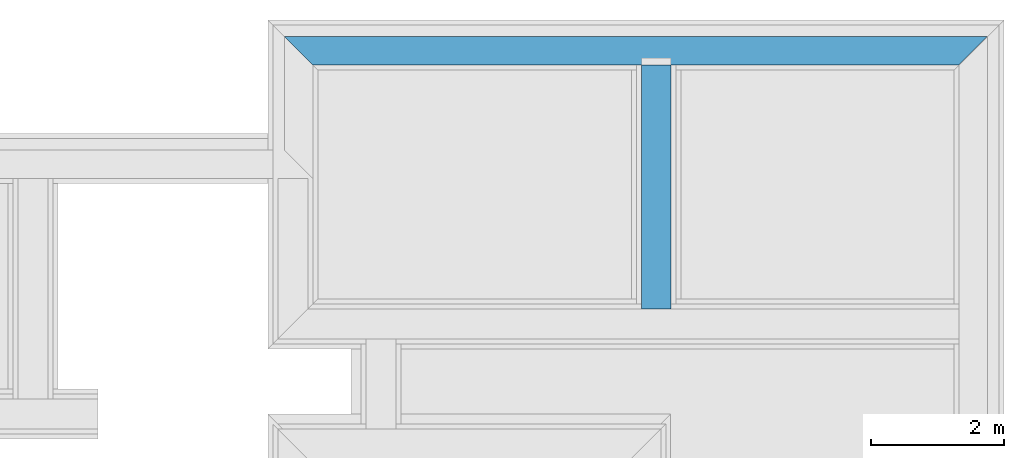
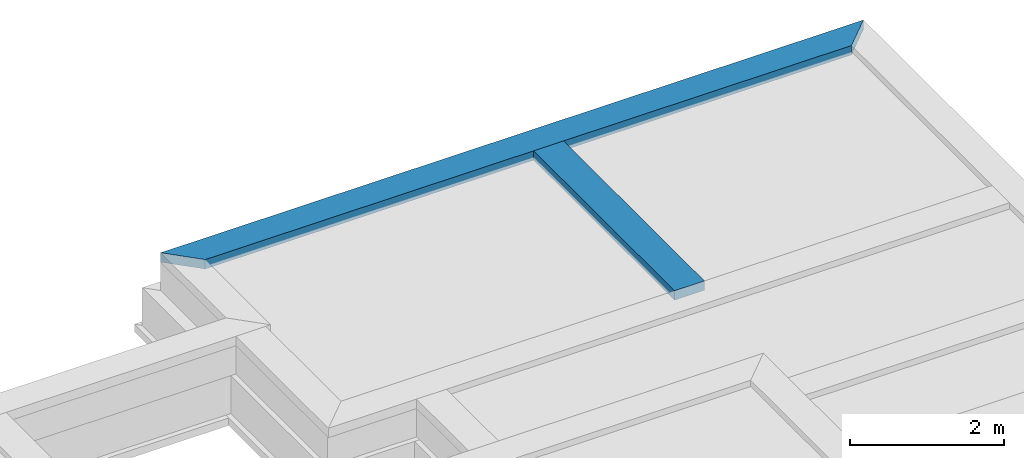
# One storey, part 2 of 7: 2 beams.
"""IFC4X3_ADD2 building model written with IfcOpenShell, lengths in metres."""

import ifcopenshell
import ifcopenshell.guid

model = None  # the IFC model being written
_history = None  # IfcOwnerHistory: only IFC2X3 demands one
_inside = {}  # id of a spatial element -> (the spatial element, [elements in it])
_under = {}  # id of a project, library or spatial element -> (it, [spatial elements below it])
_declared = {}  # id of a project -> (the project, [libraries it declares])
_typed = {}  # id of a type object -> (the type object, [elements of that type])
_made_of = {}  # id of a material, layer set ... -> (it, [elements and type objects made of it])


def new_model(schema):
    """Start an empty IFC model of exactly this schema.

    Asked for "IFC4X3", IfcOpenShell would pick the latest addendum, in which some entities
    have other attributes; the version numbers below select the first issue.
    IFC2X3 requires an IfcOwnerHistory on every rooted entity: one is made here for all.
    """
    global model, _history
    if schema == "IFC4X3":
        model = ifcopenshell.file(schema_version=(4, 3, 0, 0))
    else:
        model = ifcopenshell.file(schema=schema)
    _inside.clear()
    _under.clear()
    _declared.clear()
    _typed.clear()
    _made_of.clear()
    _history = None
    if model.schema == "IFC2X3":
        org = make("IfcOrganization", Name="unknown")
        user = make(
            "IfcPersonAndOrganization",
            ThePerson=make("IfcPerson", FamilyName="unknown"),
            TheOrganization=org,
        )
        app = make(
            "IfcApplication",
            ApplicationDeveloper=org,
            Version="unknown",
            ApplicationFullName="unknown",
            ApplicationIdentifier="unknown",
        )
        _history = make(
            "IfcOwnerHistory",
            OwningUser=user,
            OwningApplication=app,
            ChangeAction="ADDED",
            CreationDate=0,
        )
    return model


def make(cls, **values):
    """One entity of the class cls with the attributes given. An attribute that is None is left unset."""
    return model.create_entity(
        cls, **{name: value for name, value in values.items() if value is not None}
    )


def entity(cls, *values):
    """Any entity or typed value of the class cls, its attributes in the order of the schema. None: left unset."""
    e = model.create_entity(cls)
    for i, value in enumerate(values):
        if value is not None:
            e[i] = value
    return e


def rooted(cls, **values):
    """An entity with a GlobalId (a new one), such as an element, a storey or a relation."""
    return make(cls, GlobalId=ifcopenshell.guid.new(), OwnerHistory=_history, **values)


def si_unit(unit_type, name, prefix=None):
    """IfcSIUnit, for example si_unit("LENGTHUNIT", "METRE", prefix="MILLI")."""
    return make("IfcSIUnit", UnitType=unit_type, Prefix=prefix, Name=name)


def converted_unit(unit_type, name, factor, base, dimensions=None, offset=None):
    """IfcConversionBasedUnit, such as the inch: factor (a typed value) times the base unit."""
    return make(
        "IfcConversionBasedUnit"
        if offset is None
        else "IfcConversionBasedUnitWithOffset",
        ConversionOffset=offset,
        Dimensions=None
        if dimensions is None
        else entity("IfcDimensionalExponents", *dimensions),
        UnitType=unit_type,
        Name=name,
        ConversionFactor=make(
            "IfcMeasureWithUnit", ValueComponent=factor, UnitComponent=base
        ),
    )


def assignment(units):
    """IfcUnitAssignment: the units of a project."""
    return None if units is None else make("IfcUnitAssignment", Units=units)


def point(xyz):
    """IfcCartesianPoint."""
    return None if xyz is None else make("IfcCartesianPoint", Coordinates=xyz)


def direction(xyz):
    """IfcDirection."""
    return None if xyz is None else make("IfcDirection", DirectionRatios=xyz)


def frame(location, z_axis=None, x_axis=None):
    """IfcAxis2Placement3D, a coordinate frame: its origin and axes. An axis left out is left unset."""
    return make(
        "IfcAxis2Placement3D",
        Location=point(location),
        Axis=direction(z_axis),
        RefDirection=direction(x_axis),
    )


def frame_2d(location, x_axis=None):
    """IfcAxis2Placement2D, a coordinate frame in the plane: its origin and x axis."""
    return make(
        "IfcAxis2Placement2D", Location=point(location), RefDirection=direction(x_axis)
    )


def origin_with_axes():
    """The frame at (0, 0, 0) with the z axis (0, 0, 1) and the x axis (1, 0, 0) written out."""
    return frame((0.0, 0.0, 0.0), z_axis=(0.0, 0.0, 1.0), x_axis=(1.0, 0.0, 0.0))


def origin_2d_with_axis():
    """The frame at (0, 0) in the plane with the x axis (1, 0) written out."""
    return frame_2d((0.0, 0.0), x_axis=(1.0, 0.0))


def place(relative_to, where):
    """IfcLocalPlacement: puts the frame where relative to a parent placement (None: the world)."""
    return make(
        "IfcLocalPlacement", PlacementRelTo=relative_to, RelativePlacement=where
    )


def context(
    kind, dimensions, precision=None, world=None, true_north=None, identifier=None
):
    """IfcGeometricRepresentationContext, for example the 3D "Model" context."""
    return make(
        "IfcGeometricRepresentationContext",
        ContextIdentifier=identifier,
        ContextType=kind,
        CoordinateSpaceDimension=dimensions,
        Precision=precision,
        WorldCoordinateSystem=world,
        TrueNorth=true_north,
    )


def subcontext(parent, identifier, kind, view, scale=None):
    """IfcGeometricRepresentationSubContext, for example "Body" below "Model"."""
    return make(
        "IfcGeometricRepresentationSubContext",
        ContextIdentifier=identifier,
        ContextType=kind,
        ParentContext=parent,
        TargetScale=scale,
        TargetView=view,
    )


def project(units=None, contexts=None):
    """IfcProject with its units and contexts."""
    return rooted(
        "IfcProject",
        Name="project",
        RepresentationContexts=contexts,
        UnitsInContext=assignment(units),
    )


def spatial(cls, under=None, at=None, **own):
    """A site, building, storey or space (cls), placed at a placement, below another one or the project."""
    s = rooted(cls, ObjectPlacement=at, **own)
    if under is not None:
        _under.setdefault(under.id(), (under, []))[1].append(s)
    return s


def point_list(points):
    """IfcCartesianPointList2D or 3D."""
    cls = (
        "IfcCartesianPointList2D" if len(points[0]) == 2 else "IfcCartesianPointList3D"
    )
    return make(cls, CoordList=points)


def line(*indices):
    """IfcLineIndex: a straight run through numbered points of an indexed curve."""
    return model.create_entity("IfcLineIndex", indices)


def indexed_curve(points, segments=None, self_intersect=None):
    """IfcIndexedPolyCurve: lines and arcs through numbered points (the first is 1)."""
    return make(
        "IfcIndexedPolyCurve",
        Points=point_list(points),
        Segments=segments,
        SelfIntersect=self_intersect,
    )


def outline(outer, holes=None, kind="AREA"):
    """IfcArbitraryClosedProfileDef: a profile drawn as a closed curve; with holes, ...WithVoids."""
    if holes is None:
        return make("IfcArbitraryClosedProfileDef", ProfileType=kind, OuterCurve=outer)
    return make(
        "IfcArbitraryProfileDefWithVoids",
        ProfileType=kind,
        OuterCurve=outer,
        InnerCurves=holes,
    )


def extrude(swept, where, along, depth):
    """IfcExtrudedAreaSolid: the profile swept, set in the frame where, extruded along a direction by depth."""
    return make(
        "IfcExtrudedAreaSolid",
        SweptArea=swept,
        Position=where,
        ExtrudedDirection=direction(along),
        Depth=depth,
    )


def shape(context_of_items, identifier, shape_type, items):
    """IfcShapeRepresentation: the items that make up one representation, for example the "Body"."""
    return make(
        "IfcShapeRepresentation",
        ContextOfItems=context_of_items,
        RepresentationIdentifier=identifier,
        RepresentationType=shape_type,
        Items=items,
    )


def material(Name=None, Category=None):
    """IfcMaterial."""
    return make("IfcMaterial", Name=Name, Category=Category)


def layer(
    of_material, thickness, ventilated=None, Name=None, Category=None, Priority=None
):
    """IfcMaterialLayer: one layer of a wall or slab, of a material (None: an air gap)."""
    return make(
        "IfcMaterialLayer",
        Material=of_material,
        LayerThickness=thickness,
        IsVentilated=ventilated,
        Name=Name,
        Category=Category,
        Priority=Priority,
    )


def layer_set(layers, Name=None):
    """IfcMaterialLayerSet."""
    return make("IfcMaterialLayerSet", MaterialLayers=layers, LayerSetName=Name)


def layer_usage(for_layer_set, set_direction, sense, offset, extent=None):
    """IfcMaterialLayerSetUsage: how a layer set lies in its element."""
    return make(
        "IfcMaterialLayerSetUsage",
        ForLayerSet=for_layer_set,
        LayerSetDirection=set_direction,
        DirectionSense=sense,
        OffsetFromReferenceLine=offset,
        ReferenceExtent=extent,
    )


def made_of(thing, what):
    """Note that an element or type object is made of a material, layer set ...; save() writes the relation."""
    if what is not None:
        _made_of.setdefault(what.id(), (what, []))[1].append(thing)
    return thing


def type_object(cls, material=None, **own):
    """A type object (cls), such as IfcWallType, which elements share."""
    return made_of(rooted(cls, **own), material)


def element(
    cls,
    number,
    at=None,
    inside=None,
    cuts=None,
    type_object=None,
    material=None,
    context=None,
    identifier="Body",
    shape_type=None,
    held_by="IfcProductDefinitionShape",
    body=None,
    shapes=None,
    **own,
):
    """One element of the class cls, such as IfcWall. Its Tag is "e" and its number.

    at: its placement. inside: the storey or other place that contains it. cuts: it is an
    opening in that element (IfcRelVoidsElement). A single representation is given by context,
    identifier, shape_type and body (its items); several are given by shapes. held_by: the class
    of the entity that holds the representations. save() writes the other relations.
    """
    e = rooted(cls, Tag="e%d" % number, ObjectPlacement=at, **own)
    if body is not None:
        shapes = [shape(context, identifier, shape_type, body)]
    if shapes is not None:
        e.Representation = make(held_by, Representations=shapes)
    if inside is not None:
        _inside.setdefault(inside.id(), (inside, []))[1].append(e)
    if cuts is not None:
        rooted(
            "IfcRelVoidsElement", RelatingBuildingElement=cuts, RelatedOpeningElement=e
        )
    if type_object is not None:
        _typed.setdefault(type_object.id(), (type_object, []))[1].append(e)
    return made_of(e, material)


def aggregate(whole, parts):
    """IfcRelAggregates: a whole, such as a stair, and the parts it consists of."""
    return rooted("IfcRelAggregates", RelatingObject=whole, RelatedObjects=parts)


def save(model, path):
    """Write the relations noted so far, then the file.

    IfcRelAggregates (storeys below a building ...), IfcRelContainedInSpatialStructure (elements
    in a storey), IfcRelDefinesByType, IfcRelAssociatesMaterial and IfcRelDeclares: one each for
    every whole, place, type object, material and project.
    """
    for whole, parts in _under.values():
        aggregate(whole, parts)
    for where, things in _inside.values():
        rooted(
            "IfcRelContainedInSpatialStructure",
            RelatedElements=things,
            RelatingStructure=where,
        )
    for kind, things in _typed.values():
        rooted("IfcRelDefinesByType", RelatedObjects=things, RelatingType=kind)
    for what, things in _made_of.values():
        rooted("IfcRelAssociatesMaterial", RelatedObjects=things, RelatingMaterial=what)
    for by, libraries in _declared.values():
        rooted("IfcRelDeclares", RelatingContext=by, RelatedDefinitions=libraries)
    model.write(path)


model = new_model("IFC4X3_ADD2")

# Units and contexts
model_context = context("Model", 3, precision=1e-05, world=origin_with_axes())
plan_context = context("Plan", 2, precision=1e-05, world=origin_2d_with_axis())
body_context = subcontext(model_context, "Body", "Model", "MODEL_VIEW")
ifc_project = project(units=[si_unit("VOLUMEUNIT", "CUBIC_METRE"), si_unit("LENGTHUNIT", "METRE"), converted_unit("PLANEANGLEUNIT", "degree", entity("IfcReal", 0.0174532925199433), si_unit("PLANEANGLEUNIT", "RADIAN"), dimensions=[0, 0, 0, 0, 0, 0, 0]), si_unit("AREAUNIT", "SQUARE_METRE")], contexts=[model_context, plan_context])

# Site, building, storey
site_placement = place(None, origin_with_axes())
site = spatial("IfcSite", under=ifc_project, at=site_placement)
building_placement = place(site_placement, origin_with_axes())
building = spatial("IfcBuilding", under=site, at=building_placement, Name="Building")
storey_placement = place(building_placement, frame((0.0, 0.0, -0.870000004768372), z_axis=(0.0, 0.0, 1.0), x_axis=(1.0, 0.0, 0.0)))
storey = spatial("IfcBuildingStorey", under=building, at=storey_placement, Name="Footing")

# Beams
ifc_material_1 = material(Name="brick2", Category="Materials")
ifc_layer_1 = layer(ifc_material_1, 0.00999999977648258)
ifc_material_2 = material(Name="Concrete")
ifc_layer_2 = layer(ifc_material_2, 0.405000001192093)
ifc_layer_3 = layer(ifc_material_1, 0.00999999977648258)
ifc_layer_set_1 = layer_set([ifc_layer_1, ifc_layer_2, ifc_layer_3], Name="concrete")
ifc_layer_usage_1 = layer_usage(ifc_layer_set_1, "AXIS2", "POSITIVE", 0.0)
beam_type_1 = type_object("IfcBeamType", Name="425mm wide beam", PredefinedType="BEAM", material=ifc_layer_set_1)
beam_1_placement = place(storey_placement, frame((18.1166839599609, 25.9979019209745, 1.16999995708466), z_axis=(0.0, 0.0, 1.0), x_axis=(0.999999999999936, 3.57627868652321e-07, 0.0)))
element("IfcBeam", 1, at=beam_1_placement, inside=storey, type_object=beam_type_1, material=ifc_layer_usage_1, Name="Beam", context=body_context, shape_type="SweptSolid", body=[
    extrude(outline(indexed_curve([(0.425000000745059, 0.0), (2.51619385810791e-08, 0.425000000745058), (10.569989032995, 0.425000000745058), (10.1449890136726, 0.0)], segments=[line(1, 2, 3, 4, 1)])), origin_with_axes(), (0.0, 0.0, 1.0), 0.150000005960464),
])
ifc_layer_4 = layer(ifc_material_1, 0.00999999977648258)
ifc_material_3 = material(Name="Stone", Category="Structure")
ifc_layer_5 = layer(ifc_material_3, 0.430000007152557)
ifc_layer_6 = layer(ifc_material_1, 0.00999999977648258)
ifc_layer_set_2 = layer_set([ifc_layer_4, ifc_layer_5, ifc_layer_6], Name="concrete")
ifc_layer_usage_2 = layer_usage(ifc_layer_set_2, "AXIS2", "POSITIVE", 0.0)
beam_type_2 = type_object("IfcBeamType", Name="450mm wide beam", PredefinedType="BEAM", material=ifc_layer_set_2)
beam_2_placement = place(storey_placement, frame((23.4816800811879, 25.9979038396466, 1.16999995708466), z_axis=(0.0, 0.0, 1.0), x_axis=(3.13916473260163e-07, -0.999999999999951, 0.0)))
element("IfcBeam", 2, at=beam_2_placement, inside=storey, type_object=beam_type_2, material=ifc_layer_usage_2, Name="Beam", context=body_context, shape_type="SweptSolid", body=[
    extrude(outline(indexed_curve([(0.0, 0.0), (-1.96701282195799e-08, 0.450000006705522), (3.67000913781649, 0.450000006705522), (3.67000915865293, 0.0)], segments=[line(1, 2, 3, 4, 1)])), origin_with_axes(), (0.0, 0.0, 1.0), 0.150000005960464),
])

save(model, "model.ifc")
